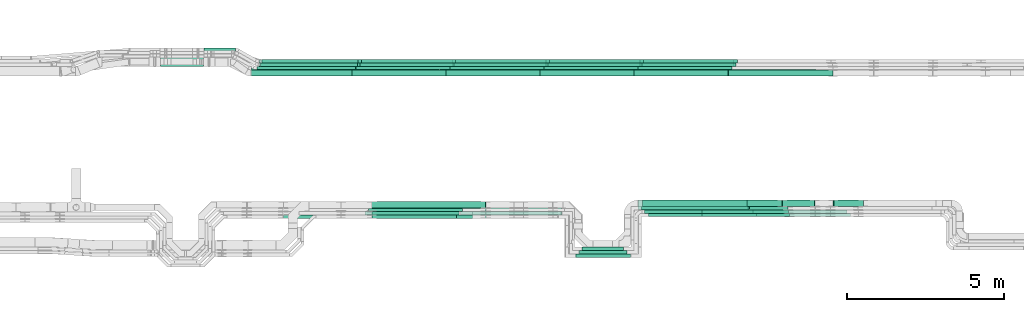
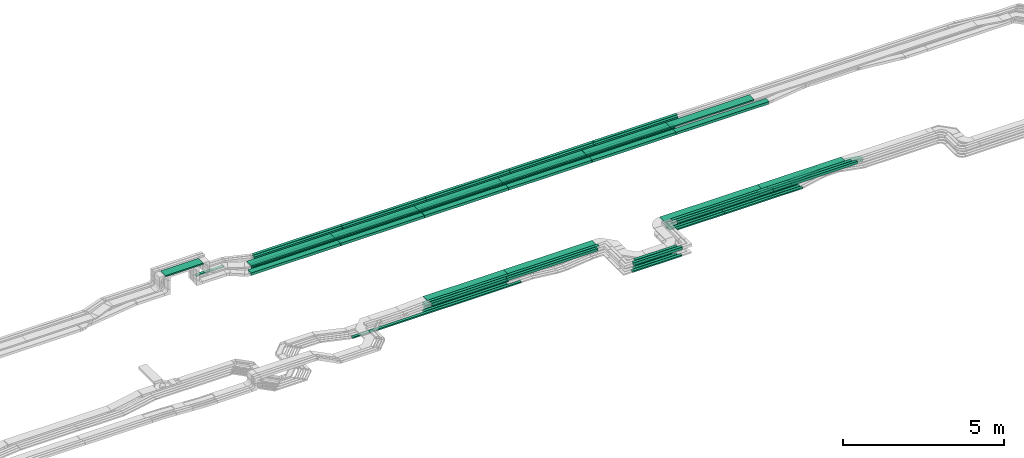
# One storey, part 3 of 33: 70 flow segments.
"""IFC2X3 building model written with IfcOpenShell, lengths in millimetres."""

from ifc_helpers import new_model, entity, si_unit, converted_unit, derived_unit, direction, frame, frame_2d, origin, origin_2d_with_axis, place, context, subcontext, project, spatial, rectangle, extrude, type_object, element, save


model = new_model("IFC2X3")

# Units and contexts
model_context = context("Model", 3, precision=0.01, world=origin(), true_north=direction((6.12303176911189e-17, 1.0)))
body_context = subcontext(model_context, "Body", "Model", "MODEL_VIEW")
ifc_project = project(units=[si_unit("LENGTHUNIT", "METRE", prefix="MILLI"), si_unit("AREAUNIT", "SQUARE_METRE"), si_unit("VOLUMEUNIT", "CUBIC_METRE"), converted_unit("PLANEANGLEUNIT", "DEGREE", entity("IfcRatioMeasure", 0.0174532925199433), si_unit("PLANEANGLEUNIT", "RADIAN"), dimensions=[0, 0, 0, 0, 0, 0, 0]), si_unit("MASSUNIT", "GRAM", prefix="KILO"), derived_unit("MASSDENSITYUNIT", [(si_unit("MASSUNIT", "GRAM", prefix="KILO"), 1), (si_unit("LENGTHUNIT", "METRE"), -3)]), derived_unit("MOMENTOFINERTIAUNIT", [(si_unit("LENGTHUNIT", "METRE"), 4)]), si_unit("TIMEUNIT", "SECOND"), si_unit("FREQUENCYUNIT", "HERTZ"), si_unit("THERMODYNAMICTEMPERATUREUNIT", "DEGREE_CELSIUS"), derived_unit("THERMALTRANSMITTANCEUNIT", [(si_unit("MASSUNIT", "GRAM", prefix="KILO"), 1), (si_unit("THERMODYNAMICTEMPERATUREUNIT", "KELVIN"), -1), (si_unit("TIMEUNIT", "SECOND"), -3)]), derived_unit("VOLUMETRICFLOWRATEUNIT", [(si_unit("LENGTHUNIT", "METRE"), 3), (si_unit("TIMEUNIT", "SECOND"), -1)]), derived_unit("MASSFLOWRATEUNIT", [(si_unit("MASSUNIT", "GRAM", prefix="KILO"), 1), (si_unit("TIMEUNIT", "SECOND"), -1)]), derived_unit("ROTATIONALFREQUENCYUNIT", [(si_unit("TIMEUNIT", "SECOND"), -1)]), si_unit("ELECTRICCURRENTUNIT", "AMPERE"), si_unit("ELECTRICVOLTAGEUNIT", "VOLT"), si_unit("POWERUNIT", "WATT"), si_unit("FORCEUNIT", "NEWTON", prefix="KILO"), si_unit("ILLUMINANCEUNIT", "LUX"), si_unit("LUMINOUSFLUXUNIT", "LUMEN"), si_unit("LUMINOUSINTENSITYUNIT", "CANDELA"), derived_unit("USERDEFINED", [(si_unit("MASSUNIT", "GRAM", prefix="KILO"), -1), (si_unit("LENGTHUNIT", "METRE"), -2), (si_unit("TIMEUNIT", "SECOND"), 3), (si_unit("LUMINOUSFLUXUNIT", "LUMEN"), 1)]), derived_unit("LINEARVELOCITYUNIT", [(si_unit("LENGTHUNIT", "METRE"), 1), (si_unit("TIMEUNIT", "SECOND"), -1)]), si_unit("PRESSUREUNIT", "PASCAL"), derived_unit("USERDEFINED", [(si_unit("LENGTHUNIT", "METRE"), -2), (si_unit("MASSUNIT", "GRAM", prefix="KILO"), 1), (si_unit("TIMEUNIT", "SECOND"), -2)]), derived_unit("LINEARFORCEUNIT", [(si_unit("MASSUNIT", "GRAM", prefix="KILO"), 1), (si_unit("LENGTHUNIT", "METRE"), 1), (si_unit("TIMEUNIT", "SECOND"), -2), (si_unit("LENGTHUNIT", "METRE"), -1)]), derived_unit("PLANARFORCEUNIT", [(si_unit("MASSUNIT", "GRAM", prefix="KILO"), 1), (si_unit("LENGTHUNIT", "METRE"), 1), (si_unit("TIMEUNIT", "SECOND"), -2), (si_unit("LENGTHUNIT", "METRE"), -2)])], contexts=[model_context])

# Site, building, storey
site_placement = place(None, frame((0.0, -0.00077364408347762, 0.0)))
site = spatial("IfcSite", under=ifc_project, at=site_placement, CompositionType="ELEMENT")
building_placement = place(site_placement, origin())
building = spatial("IfcBuilding", under=site, at=building_placement, CompositionType="ELEMENT")
storey_placement = place(building_placement, frame((0.0, 0.0, 8100.0)))
storey = spatial("IfcBuildingStorey", under=building, at=storey_placement, CompositionType="ELEMENT", Elevation=8100.0)

# Flow segments
cable_carrier_segment_type = type_object("IfcCableCarrierSegmentType", PredefinedType="CABLETRAYSEGMENT")
flow_segment_1_placement = place(storey_placement, frame((39344.2553602729, 9754.99855346678, 2800.01096864733)))
element("IfcFlowSegment", 1, at=flow_segment_1_placement, inside=storey, type_object=cable_carrier_segment_type, context=body_context, shape_type="SweptSolid", body=[
    extrude(rectangle(XDim=3242.93310217294, YDim=99.9999999999989, at=frame_2d((-4.32009983342141e-12, 1.08357767203415e-12), x_axis=(1.0, 0.0))), frame((1621.46655108647, 50.0, 0.0), z_axis=(0.0, 0.0, 1.0), x_axis=(-1.0, 0.0, 0.0)), (0.0, 0.0, 1.0), 100.000000000001),
])
flow_segment_2_placement = place(storey_placement, frame((39398.0989392992, 9874.99855346679, 2800.01711339307)))
element("IfcFlowSegment", 2, at=flow_segment_2_placement, inside=storey, type_object=cable_carrier_segment_type, context=body_context, shape_type="SweptSolid", body=[
    extrude(rectangle(XDim=3173.08952314652, YDim=300.000000000001, at=frame_2d((0.0, -1.08002495835535e-12), x_axis=(1.0, 0.0))), frame((1586.54476157326, 150.0, 0.0), z_axis=(0.0, 0.0, 1.0), x_axis=(-1.0, 0.0, 0.0)), (0.0, 0.0, 1.0), 50.0000000000016),
])
flow_segment_3_placement = place(storey_placement, frame((31166.4130823037, 14970.0572451366, 2548.86724903677)))
element("IfcFlowSegment", 3, at=flow_segment_3_placement, inside=storey, type_object=cable_carrier_segment_type, context=body_context, shape_type="SweptSolid", body=[
    extrude(rectangle(XDim=998.256803593107, YDim=99.9999999999989, at=frame_2d((2.1600499167107e-12, 2.16715534406831e-12), x_axis=(1.0, 0.0))), frame((499.128401796551, 50.0, 0.0)), (0.0, 0.0, 1.0), 50.0000000000016),
])
flow_segment_4_placement = place(storey_placement, frame((29783.1990989324, 14480.0572451366, 3324.99867972438)))
element("IfcFlowSegment", 4, at=flow_segment_4_placement, inside=storey, type_object=cable_carrier_segment_type, context=body_context, shape_type="SweptSolid", body=[
    extrude(rectangle(XDim=1363.2139833713, YDim=300.000000000001, at=origin_2d_with_axis()), frame((681.606991685648, 150.0, 0.0)), (0.0, 0.0, 1.0), 50.0000000000016),
])
flow_segment_5_placement = place(storey_placement, frame((45344.895803197, 9694.9904366488, 2799.26960057867)))
element("IfcFlowSegment", 5, at=flow_segment_5_placement, inside=storey, type_object=cable_carrier_segment_type, context=body_context, shape_type="SweptSolid", body=[
    extrude(rectangle(XDim=99.9999999999999, YDim=3442.93310217287, at=frame_2d((-4.32009983342141e-12, -5.43565192856477e-13), x_axis=(0.0, 1.0))), frame((1721.46655109041, 49.9999989516433, 0.0109305123649392), z_axis=(4.01733183785302e-07, 0.000204778842241825, 0.999999979032732), x_axis=(1.0, 0.0, -4.01733192208904e-07)), (0.0, 0.0, 1.0), 100.0),
])
flow_segment_6_placement = place(storey_placement, frame((43147.1884624458, 8512.68960275249, 2800.01096864734)))
element("IfcFlowSegment", 6, at=flow_segment_6_placement, inside=storey, type_object=cable_carrier_segment_type, context=body_context, shape_type="SweptSolid", body=[
    extrude(rectangle(XDim=1512.20104272159, YDim=100.000000000001, at=frame_2d((0.0, 5.43565192856477e-13), x_axis=(1.0, 0.0))), frame((756.100521360796, 50.0, 0.0)), (0.0, 0.0, 1.0), 99.9999999999989),
])
flow_segment_7_placement = place(storey_placement, frame((43027.1884624458, 8402.69104941503, 2799.2813532093)))
element("IfcFlowSegment", 7, at=flow_segment_7_placement, inside=storey, type_object=cable_carrier_segment_type, context=body_context, shape_type="SweptSolid", body=[
    extrude(rectangle(XDim=1757.70736084199, YDim=100.000000000001, at=frame_2d((0.0, 5.43565192856477e-13), x_axis=(1.0, 0.0))), frame((878.853680420995, 50.0, 0.0)), (0.0, 0.0, 1.0), 99.9999999999989),
])
flow_segment_8_placement = place(storey_placement, frame((43217.1884624458, 8622.68960275249, 2544.92549664435)))
element("IfcFlowSegment", 8, at=flow_segment_8_placement, inside=storey, type_object=cable_carrier_segment_type, context=body_context, shape_type="SweptSolid", body=[
    extrude(rectangle(XDim=1332.2010427216, YDim=99.9999999999989, at=frame_2d((0.0, 5.40012479177676e-13), x_axis=(1.0, 0.0))), frame((666.100521360799, 50.0, 0.0)), (0.0, 0.0, 1.0), 50.0000000000016),
])
flow_segment_9_placement = place(storey_placement, frame((43107.1884624458, 8512.68960275249, 2546.31908538351)))
element("IfcFlowSegment", 9, at=flow_segment_9_placement, inside=storey, type_object=cable_carrier_segment_type, context=body_context, shape_type="SweptSolid", body=[
    extrude(rectangle(XDim=1552.2010427216, YDim=99.9999999999989, at=frame_2d((0.0, 5.40012479177676e-13), x_axis=(1.0, 0.0))), frame((776.1005213608, 50.0, 0.0)), (0.0, 0.0, 1.0), 50.0000000000016),
])
flow_segment_10_placement = place(storey_placement, frame((42997.1884624458, 8402.69104941504, 2546.66940793271)))
element("IfcFlowSegment", 10, at=flow_segment_10_placement, inside=storey, type_object=cable_carrier_segment_type, context=body_context, shape_type="SweptSolid", body=[
    extrude(rectangle(XDim=1772.70736117974, YDim=100.000000000001, at=frame_2d((0.0, -5.43565192856477e-13), x_axis=(1.0, 0.0))), frame((886.353680589868, 50.0, 0.0)), (0.0, 0.0, 1.0), 50.0000000000016),
])
flow_segment_11_placement = place(storey_placement, frame((32683.4984883603, 14182.2782357472, 2854.49733895749)))
element("IfcFlowSegment", 11, at=flow_segment_11_placement, inside=storey, type_object=cable_carrier_segment_type, context=body_context, shape_type="SweptSolid", body=[
    extrude(rectangle(XDim=2998.73000000508, YDim=300.000000000001, at=frame_2d((-2.1600499167107e-12, 0.0), x_axis=(1.0, 0.0))), frame((1499.36500000255, 150.0, 0.0)), (0.0, 0.0, 1.0), 50.0000000000016),
])
flow_segment_12_placement = place(storey_placement, frame((32966.2723263535, 14492.2782357466, 2855.0)))
element("IfcFlowSegment", 12, at=flow_segment_12_placement, inside=storey, type_object=cable_carrier_segment_type, context=body_context, shape_type="SweptSolid", body=[
    extrude(rectangle(XDim=3170.75891996771, YDim=99.9999999999989, at=origin_2d_with_axis()), frame((1585.37945998386, 50.0, 0.0)), (0.0, 0.0, 1.0), 99.9999999999989),
])
flow_segment_13_placement = place(storey_placement, frame((33011.9130635549, 14602.2782357466, 2855.0)))
element("IfcFlowSegment", 13, at=flow_segment_13_placement, inside=storey, type_object=cable_carrier_segment_type, context=body_context, shape_type="SweptSolid", body=[
    extrude(rectangle(XDim=3172.25095291534, YDim=99.9999999999989, at=frame_2d((-2.1600499167107e-12, 1.08357767203415e-12), x_axis=(1.0, 0.0))), frame((1586.12547645767, 50.0, 0.0)), (0.0, 0.0, 1.0), 99.9999999999989),
])
flow_segment_14_placement = place(storey_placement, frame((32920.1040531699, 14602.2782357466, 2548.86724903677)))
element("IfcFlowSegment", 14, at=flow_segment_14_placement, inside=storey, type_object=cable_carrier_segment_type, context=body_context, shape_type="SweptSolid", body=[
    extrude(rectangle(XDim=3151.80224385144, YDim=99.9999999999989, at=frame_2d((-2.1600499167107e-12, 0.0), x_axis=(1.0, 0.0))), frame((1575.90112192572, 50.0, 0.0)), (0.0, 0.0, 1.0), 50.0000000000016),
])
flow_segment_15_placement = place(storey_placement, frame((32914.6272166051, 14492.2782357466, 2548.34838425104)))
element("IfcFlowSegment", 15, at=flow_segment_15_placement, inside=storey, type_object=cable_carrier_segment_type, context=body_context, shape_type="SweptSolid", body=[
    extrude(rectangle(XDim=3151.80224385145, YDim=99.9999999999989, at=frame_2d((4.43378667114303e-12, -1.08357767203415e-12), x_axis=(1.0, 0.0))), frame((1575.90112192572, 50.0, 0.0)), (0.0, 0.0, 1.0), 50.0000000000016),
])
flow_segment_16_placement = place(storey_placement, frame((32852.1769039827, 14382.2782357466, 2548.879926104)))
element("IfcFlowSegment", 16, at=flow_segment_16_placement, inside=storey, type_object=cable_carrier_segment_type, context=body_context, shape_type="SweptSolid", body=[
    extrude(rectangle(XDim=3151.80224385145, YDim=99.9999999999989, at=frame_2d((-2.1600499167107e-12, -1.08357767203415e-12), x_axis=(1.0, 0.0))), frame((1575.90112192573, 50.0, 0.0)), (0.0, 0.0, 1.0), 50.0000000000016),
])
flow_segment_17_placement = place(storey_placement, frame((47050.0315011744, 9804.99937591543, 2546.31908538351)))
element("IfcFlowSegment", 17, at=flow_segment_17_placement, inside=storey, type_object=cable_carrier_segment_type, context=body_context, shape_type="SweptSolid", body=[
    extrude(rectangle(XDim=2747.08735792927, YDim=99.9999999999989, at=origin_2d_with_axis()), frame((1373.54367896464, 50.0, 0.0)), (0.0, 0.0, 1.0), 50.0000000000016),
])
flow_segment_18_placement = place(storey_placement, frame((45109.3895051674, 9914.99937591541, 2544.92549664435)))
element("IfcFlowSegment", 18, at=flow_segment_18_placement, inside=storey, type_object=cable_carrier_segment_type, context=body_context, shape_type="SweptSolid", body=[
    extrude(rectangle(XDim=3442.93310217291, YDim=99.9999999999989, at=frame_2d((-4.32009983342141e-12, 0.0), x_axis=(1.0, 0.0))), frame((1721.46655108646, 50.0, 0.0)), (0.0, 0.0, 1.0), 50.0000000000016),
])
flow_segment_19_placement = place(storey_placement, frame((45145.3895051674, 10024.9993759154, 2547.39498136108)))
element("IfcFlowSegment", 19, at=flow_segment_19_placement, inside=storey, type_object=cable_carrier_segment_type, context=body_context, shape_type="SweptSolid", body=[
    extrude(rectangle(XDim=3327.94024484785, YDim=200.000000000002, at=frame_2d((0.0, -1.08713038571295e-12), x_axis=(1.0, 0.0))), frame((1663.97012242393, 100.0, 0.0)), (0.0, 0.0, 1.0), 99.9999999999989),
])
flow_segment_20_placement = place(storey_placement, frame((47050.0315011743, 9695.00084987848, 2546.66940793271)))
element("IfcFlowSegment", 20, at=flow_segment_20_placement, inside=storey, type_object=cable_carrier_segment_type, context=body_context, shape_type="SweptSolid", body=[
    extrude(rectangle(XDim=2786.58976200292, YDim=99.9999999999989, at=origin_2d_with_axis()), frame((1393.29488100146, 50.0, 0.0)), (0.0, 0.0, 1.0), 50.0000000000016),
])
flow_segment_21_placement = place(storey_placement, frame((32672.4468332395, 14174.499226356, 2548.87698397101)))
element("IfcFlowSegment", 21, at=flow_segment_21_placement, inside=storey, type_object=cable_carrier_segment_type, context=body_context, shape_type="SweptSolid", body=[
    extrude(rectangle(XDim=3209.55577942012, YDim=200.000000000002, at=frame_2d((-2.1600499167107e-12, 1.08713038571295e-12), x_axis=(1.0, 0.0))), frame((1604.77788971006, 100.0, 0.0)), (0.0, 0.0, 1.0), 99.9999999999989),
])
flow_segment_22_placement = place(storey_placement, frame((39224.2553602729, 9644.99855346678, 2799.2813532093)))
element("IfcFlowSegment", 22, at=flow_segment_22_placement, inside=storey, type_object=cable_carrier_segment_type, context=body_context, shape_type="SweptSolid", body=[
    extrude(rectangle(XDim=3242.93310217294, YDim=100.000000000001, at=frame_2d((4.32009983342141e-12, 5.43565192856477e-13), x_axis=(1.0, 0.0))), frame((1621.46655108647, 50.0, 0.0), z_axis=(0.0, 0.0, 1.0), x_axis=(-1.0, 0.0, 0.0)), (0.0, 0.0, 1.0), 99.9999999999989),
])
flow_segment_23_placement = place(storey_placement, frame((45008.6950846977, 9924.99937591757, 2796.02568718163)))
element("IfcFlowSegment", 23, at=flow_segment_23_placement, inside=storey, type_object=cable_carrier_segment_type, context=body_context, shape_type="SweptSolid", body=[
    extrude(rectangle(XDim=3498.71922401121, YDim=299.999999995752, at=frame_2d((4.32009983342141e-12, 0.0), x_axis=(1.0, 0.0))), frame((1749.35864760649, 150.0, 1.83688889176971), z_axis=(0.00105003504091696, 0.0, 0.999999448713054), x_axis=(0.999999448713054, 0.0, -0.00105003504091696)), (0.0, 0.0, 1.0), 49.9999999992948),
])
flow_segment_24_placement = place(storey_placement, frame((45219.3885751974, 9804.9993759241, 2799.94084454103)))
element("IfcFlowSegment", 24, at=flow_segment_24_placement, inside=storey, type_object=cable_carrier_segment_type, context=body_context, shape_type="SweptSolid", body=[
    extrude(rectangle(XDim=3442.93310207175, YDim=99.9999999827077, at=frame_2d((0.0, -1.08357767203415e-12), x_axis=(1.0, 0.0))), frame((1721.46655073815, 50.0, 0.0320159615575506)), (0.0, 0.0, 1.0), 99.9999999827065),
])
flow_segment_25_placement = place(storey_placement, frame((36074.4462970112, 14602.2782357467, 2548.86724903677)))
element("IfcFlowSegment", 25, at=flow_segment_25_placement, inside=storey, type_object=cable_carrier_segment_type, context=body_context, shape_type="SweptSolid", body=[
    extrude(rectangle(XDim=2997.46000001016, YDim=99.9999999999989, at=frame_2d((2.1600499167107e-12, 0.0), x_axis=(1.0, 0.0))), frame((1498.73000000508, 50.0, 0.0)), (0.0, 0.0, 1.0), 50.0000000000016),
])
flow_segment_26_placement = place(storey_placement, frame((39074.4462970112, 14602.2782357467, 2548.86724903676)))
element("IfcFlowSegment", 26, at=flow_segment_26_placement, inside=storey, type_object=cable_carrier_segment_type, context=body_context, shape_type="SweptSolid", body=[
    extrude(rectangle(XDim=2997.46000001017, YDim=99.9999999999989, at=frame_2d((0.0, -1.08357767203415e-12), x_axis=(1.0, 0.0))), frame((1498.73000000508, 50.0, 0.0)), (0.0, 0.0, 1.0), 50.0000000000016),
])
flow_segment_27_placement = place(storey_placement, frame((42074.4462970112, 14602.2782357469, 2548.86724903676)))
element("IfcFlowSegment", 27, at=flow_segment_27_placement, inside=storey, type_object=cable_carrier_segment_type, context=body_context, shape_type="SweptSolid", body=[
    extrude(rectangle(XDim=2997.46000001017, YDim=99.9999999999989, at=frame_2d((0.0, 1.08357767203415e-12), x_axis=(1.0, 0.0))), frame((1498.73000000508, 50.0, 0.0)), (0.0, 0.0, 1.0), 50.0000000000016),
])
flow_segment_28_placement = place(storey_placement, frame((45074.4462970112, 14602.2782357471, 2548.86724903676)))
element("IfcFlowSegment", 28, at=flow_segment_28_placement, inside=storey, type_object=cable_carrier_segment_type, context=body_context, shape_type="SweptSolid", body=[
    extrude(rectangle(XDim=2997.46000001017, YDim=99.9999999999989, at=frame_2d((0.0, 2.16715534406831e-12), x_axis=(1.0, 0.0))), frame((1498.73000000508, 50.0, 0.0)), (0.0, 0.0, 1.0), 50.0000000000016),
])
flow_segment_29_placement = place(storey_placement, frame((36304.2553602729, 9754.99855346681, 2546.31908538351)))
element("IfcFlowSegment", 29, at=flow_segment_29_placement, inside=storey, type_object=cable_carrier_segment_type, context=body_context, shape_type="SweptSolid", body=[
    extrude(rectangle(XDim=2997.46000001017, YDim=99.9999999999989, at=origin_2d_with_axis()), frame((1498.73000000508, 50.0, 0.0)), (0.0, 0.0, 1.0), 50.0000000000016),
])
flow_segment_30_placement = place(storey_placement, frame((36068.9694604464, 14492.2782357468, 2548.34838425104)))
element("IfcFlowSegment", 30, at=flow_segment_30_placement, inside=storey, type_object=cable_carrier_segment_type, context=body_context, shape_type="SweptSolid", body=[
    extrude(rectangle(XDim=2997.46000001016, YDim=99.9999999999989, at=frame_2d((2.1600499167107e-12, 2.16715534406831e-12), x_axis=(1.0, 0.0))), frame((1498.73000000508, 50.0, 0.0)), (0.0, 0.0, 1.0), 50.0000000000016),
])
flow_segment_31_placement = place(storey_placement, frame((39068.9694604464, 14492.2782357468, 2548.34838425103)))
element("IfcFlowSegment", 31, at=flow_segment_31_placement, inside=storey, type_object=cable_carrier_segment_type, context=body_context, shape_type="SweptSolid", body=[
    extrude(rectangle(XDim=2997.46000001017, YDim=99.9999999999989, at=frame_2d((0.0, 2.16715534406831e-12), x_axis=(1.0, 0.0))), frame((1498.73000000508, 50.0, 0.0)), (0.0, 0.0, 1.0), 50.0000000000016),
])
flow_segment_32_placement = place(storey_placement, frame((42068.9694604464, 14492.278235747, 2548.34838425104)))
element("IfcFlowSegment", 32, at=flow_segment_32_placement, inside=storey, type_object=cable_carrier_segment_type, context=body_context, shape_type="SweptSolid", body=[
    extrude(rectangle(XDim=2997.46000001017, YDim=99.9999999999989, at=frame_2d((0.0, -1.08357767203415e-12), x_axis=(1.0, 0.0))), frame((1498.73000000508, 50.0, 0.0)), (0.0, 0.0, 1.0), 50.0000000000016),
])
flow_segment_33_placement = place(storey_placement, frame((45068.9694604464, 14492.2782357472, 2548.34838425104)))
element("IfcFlowSegment", 33, at=flow_segment_33_placement, inside=storey, type_object=cable_carrier_segment_type, context=body_context, shape_type="SweptSolid", body=[
    extrude(rectangle(XDim=2997.46000001016, YDim=99.9999999999989, at=frame_2d((-4.32009983342141e-12, 0.0), x_axis=(1.0, 0.0))), frame((1498.73000000508, 50.0, 0.0)), (0.0, 0.0, 1.0), 50.0000000000016),
])
flow_segment_34_placement = place(storey_placement, frame((45140.3895051674, 9804.99937591543, 2546.31908538351)))
element("IfcFlowSegment", 34, at=flow_segment_34_placement, inside=storey, type_object=cable_carrier_segment_type, context=body_context, shape_type="SweptSolid", body=[
    extrude(rectangle(XDim=1907.10199601725, YDim=99.9999999999989, at=origin_2d_with_axis()), frame((953.550998008623, 50.0, 0.0), z_axis=(0.0, 0.0, 1.0), x_axis=(-1.0, 0.0, 0.0)), (0.0, 0.0, 1.0), 50.0000000000016),
])
flow_segment_35_placement = place(storey_placement, frame((36139.5712463111, 14492.2782357466, 2855.0)))
element("IfcFlowSegment", 35, at=flow_segment_35_placement, inside=storey, type_object=cable_carrier_segment_type, context=body_context, shape_type="SweptSolid", body=[
    extrude(rectangle(XDim=2997.46000001016, YDim=99.9999999999989, at=frame_2d((2.1600499167107e-12, -2.16715534406831e-12), x_axis=(1.0, 0.0))), frame((1498.73000000508, 50.0, 0.0)), (0.0, 0.0, 1.0), 99.9999999999989),
])
flow_segment_36_placement = place(storey_placement, frame((39139.5712463111, 14492.2782357466, 2855.0)))
element("IfcFlowSegment", 36, at=flow_segment_36_placement, inside=storey, type_object=cable_carrier_segment_type, context=body_context, shape_type="SweptSolid", body=[
    extrude(rectangle(XDim=2997.46000001017, YDim=99.9999999999989, at=frame_2d((0.0, -2.16715534406831e-12), x_axis=(1.0, 0.0))), frame((1498.73000000508, 50.0, 0.0)), (0.0, 0.0, 1.0), 99.9999999999989),
])
flow_segment_37_placement = place(storey_placement, frame((42139.5712463111, 14492.2782357466, 2855.0)))
element("IfcFlowSegment", 37, at=flow_segment_37_placement, inside=storey, type_object=cable_carrier_segment_type, context=body_context, shape_type="SweptSolid", body=[
    extrude(rectangle(XDim=2997.46000001017, YDim=99.9999999999989, at=frame_2d((0.0, -1.08357767203415e-12), x_axis=(1.0, 0.0))), frame((1498.73000000508, 50.0, 0.0)), (0.0, 0.0, 1.0), 99.9999999999989),
])
flow_segment_38_placement = place(storey_placement, frame((45139.5712463111, 14492.2782357469, 2855.0)))
element("IfcFlowSegment", 38, at=flow_segment_38_placement, inside=storey, type_object=cable_carrier_segment_type, context=body_context, shape_type="SweptSolid", body=[
    extrude(rectangle(XDim=2997.46000001017, YDim=99.9999999999989, at=origin_2d_with_axis()), frame((1498.73000000508, 50.0, 0.0)), (0.0, 0.0, 1.0), 99.9999999999989),
])
for number, where in (
    (39, (35884.5426126494, 14174.499226356, 2548.87698397101)),
    (40, (38884.5426126494, 14174.499226356, 2548.876983971)),
):
    element("IfcFlowSegment", number, at=place(storey_placement, frame(where)), inside=storey, type_object=cable_carrier_segment_type, context=body_context, shape_type="SweptSolid", body=[
        extrude(rectangle(XDim=2997.46000001016, YDim=199.999999999998, at=frame_2d((2.1600499167107e-12, 0.0), x_axis=(1.0, 0.0))), frame((1498.73000000508, 100.0, 0.0)), (0.0, 0.0, 1.0), 99.9999999999989),
    ])
flow_segment_39_placement = place(storey_placement, frame((41884.5426126494, 14174.499226356, 2548.876983971)))
element("IfcFlowSegment", 41, at=flow_segment_39_placement, inside=storey, type_object=cable_carrier_segment_type, context=body_context, shape_type="SweptSolid", body=[
    extrude(rectangle(XDim=2997.46000001017, YDim=199.999999999998, at=frame_2d((0.0, 2.16715534406831e-12), x_axis=(1.0, 0.0))), frame((1498.73000000508, 100.0, 0.0)), (0.0, 0.0, 1.0), 99.9999999999989),
])
flow_segment_40_placement = place(storey_placement, frame((44884.5426126494, 14174.499226356, 2548.87698397099)))
element("IfcFlowSegment", 42, at=flow_segment_40_placement, inside=storey, type_object=cable_carrier_segment_type, context=body_context, shape_type="SweptSolid", body=[
    extrude(rectangle(XDim=2997.46000001016, YDim=199.999999999998, at=frame_2d((-4.32009983342141e-12, 0.0), x_axis=(1.0, 0.0))), frame((1498.73000000508, 100.0, 0.0)), (0.0, 0.0, 1.0), 99.9999999999989),
])
flow_segment_41_placement = place(storey_placement, frame((47884.5426126494, 14174.499226356, 2548.87698397099)))
element("IfcFlowSegment", 43, at=flow_segment_41_placement, inside=storey, type_object=cable_carrier_segment_type, context=body_context, shape_type="SweptSolid", body=[
    extrude(rectangle(XDim=3332.70440700738, YDim=199.999999999998, at=frame_2d((0.0, -1.08002495835535e-12), x_axis=(1.0, 0.0))), frame((1666.35220350369, 100.0, 0.0)), (0.0, 0.0, 1.0), 99.9999999999989),
])
for number, where in (
    (44, (35684.7684883553, 14182.2782357472, 2854.49733895749)),
    (45, (38684.7684883553, 14182.2782357472, 2854.49733895749)),
):
    element("IfcFlowSegment", number, at=place(storey_placement, frame(where)), inside=storey, type_object=cable_carrier_segment_type, context=body_context, shape_type="SweptSolid", body=[
        extrude(rectangle(XDim=2997.46000001016, YDim=300.000000000001, at=frame_2d((2.1600499167107e-12, 0.0), x_axis=(1.0, 0.0))), frame((1498.73000000508, 150.0, 0.0)), (0.0, 0.0, 1.0), 50.0000000000016),
    ])
flow_segment_42_placement = place(storey_placement, frame((41684.7684883553, 14182.2782357472, 2854.4973389575)))
element("IfcFlowSegment", 46, at=flow_segment_42_placement, inside=storey, type_object=cable_carrier_segment_type, context=body_context, shape_type="SweptSolid", body=[
    extrude(rectangle(XDim=2997.46000001017, YDim=300.000000000001, at=origin_2d_with_axis()), frame((1498.73000000508, 150.0, 0.0)), (0.0, 0.0, 1.0), 50.0000000000038),
])
flow_segment_43_placement = place(storey_placement, frame((44684.7684883553, 14182.2782357474, 2854.4973389575)))
element("IfcFlowSegment", 47, at=flow_segment_43_placement, inside=storey, type_object=cable_carrier_segment_type, context=body_context, shape_type="SweptSolid", body=[
    extrude(rectangle(XDim=2997.46000001017, YDim=300.000000000001, at=frame_2d((0.0, 1.08002495835535e-12), x_axis=(1.0, 0.0))), frame((1498.73000000508, 150.0, 0.0)), (0.0, 0.0, 1.0), 50.0000000000016),
])
flow_segment_44_placement = place(storey_placement, frame((47684.7684883553, 14182.2782357476, 2854.4973389575)))
element("IfcFlowSegment", 48, at=flow_segment_44_placement, inside=storey, type_object=cable_carrier_segment_type, context=body_context, shape_type="SweptSolid", body=[
    extrude(rectangle(XDim=2997.46000001016, YDim=300.000000000001, at=frame_2d((-4.32009983342141e-12, 2.17426077142591e-12), x_axis=(1.0, 0.0))), frame((1498.73000000508, 150.0, 0.0)), (0.0, 0.0, 1.0), 50.0000000000038),
])
flow_segment_45_placement = place(storey_placement, frame((36493.2395962174, 9974.99855349166, 2546.76460459149)))
element("IfcFlowSegment", 49, at=flow_segment_45_placement, inside=storey, type_object=cable_carrier_segment_type, context=body_context, shape_type="SweptSolid", body=[
    extrude(rectangle(XDim=3655.89665624518, YDim=199.999999950251, at=frame_2d((0.0, 1.08002495835535e-12), x_axis=(1.0, 0.0))), frame((1827.94830094897, 100.0, 0.31518876265219), z_axis=(0.000172427610674945, 0.0, 0.99999998513436), x_axis=(0.99999998513436, 0.0, -0.000172427610674945)), (0.0, 0.0, 1.0), 99.999999975123),
])
flow_segment_46_placement = place(storey_placement, frame((48475.8697500051, 10024.9993759154, 2547.39498136108)))
element("IfcFlowSegment", 50, at=flow_segment_46_placement, inside=storey, type_object=cable_carrier_segment_type, context=body_context, shape_type="SweptSolid", body=[
    extrude(rectangle(XDim=1127.1073315062, YDim=199.999999999998, at=frame_2d((-4.32009983342141e-12, 0.0), x_axis=(1.0, 0.0))), frame((563.553665753103, 100.0, 0.0)), (0.0, 0.0, 1.0), 99.9999999999989),
])
flow_segment_47_placement = place(storey_placement, frame((48509.9523785002, 9924.99937591544, 2792.87558205849)))
element("IfcFlowSegment", 51, at=flow_segment_47_placement, inside=storey, type_object=cable_carrier_segment_type, context=body_context, shape_type="SweptSolid", body=[
    extrude(rectangle(XDim=2997.46000001016, YDim=300.000000000001, at=frame_2d((0.0, 1.08002495835535e-12), x_axis=(1.0, 0.0))), frame((1498.72917377479, 150.0, 1.57371901689521), z_axis=(0.0010500350409279, 0.0, 0.999999448713054), x_axis=(0.999999448713054, 0.0, -0.0010500350409279)), (0.0, 0.0, 1.0), 50.0000000000008),
])
flow_segment_48_placement = place(storey_placement, frame((36414.2553602729, 9864.99855346681, 2544.92549664434)))
element("IfcFlowSegment", 52, at=flow_segment_48_placement, inside=storey, type_object=cable_carrier_segment_type, context=body_context, shape_type="SweptSolid", body=[
    extrude(rectangle(XDim=2997.46000001016, YDim=99.9999999999989, at=frame_2d((-2.1600499167107e-12, 0.0), x_axis=(1.0, 0.0))), frame((1498.73000000508, 50.0, 0.0), z_axis=(0.0, 0.0, 1.0), x_axis=(-1.0, 0.0, 0.0)), (0.0, 0.0, 1.0), 50.0000000000016),
])
flow_segment_49_placement = place(storey_placement, frame((33696.8392112639, 9644.9985534668, 2546.63308707341)))
element("IfcFlowSegment", 53, at=flow_segment_49_placement, inside=storey, type_object=cable_carrier_segment_type, context=body_context, shape_type="SweptSolid", body=[
    extrude(rectangle(XDim=6031.01020597482, YDim=100.000000000001, at=frame_2d((-2.27373675443232e-12, 0.0), x_axis=(1.0, 0.0))), frame((3015.50510298741, 50.0, 0.0), z_axis=(0.0, 0.0, 1.0), x_axis=(-1.0, 0.0, 0.0)), (0.0, 0.0, 1.0), 50.0000000000016),
])
flow_segment_50_placement = place(storey_placement, frame((48790.3689019508, 9695.00067454256, 2799.27842851121)))
element("IfcFlowSegment", 54, at=flow_segment_50_placement, inside=storey, type_object=cable_carrier_segment_type, context=body_context, shape_type="SweptSolid", body=[
    extrude(rectangle(XDim=2997.46000001017, YDim=99.9999999999989, at=origin_2d_with_axis()), frame((1498.73000000492, 50.0, 0.000704383717800283)), (0.0, 0.0, 1.0), 100.000000000001),
])
flow_segment_51_placement = place(storey_placement, frame((36186.70401646, 14602.2782357466, 2855.0)))
element("IfcFlowSegment", 55, at=flow_segment_51_placement, inside=storey, type_object=cable_carrier_segment_type, context=body_context, shape_type="SweptSolid", body=[
    extrude(rectangle(XDim=2997.46000001016, YDim=99.9999999999989, at=frame_2d((2.1600499167107e-12, 0.0), x_axis=(1.0, 0.0))), frame((1498.73000000508, 50.0, 0.0)), (0.0, 0.0, 1.0), 99.9999999999989),
])
flow_segment_52_placement = place(storey_placement, frame((39186.70401646, 14602.2782357466, 2855.0)))
element("IfcFlowSegment", 56, at=flow_segment_52_placement, inside=storey, type_object=cable_carrier_segment_type, context=body_context, shape_type="SweptSolid", body=[
    extrude(rectangle(XDim=2997.46000001017, YDim=99.9999999999989, at=origin_2d_with_axis()), frame((1498.73000000508, 50.0, 0.0)), (0.0, 0.0, 1.0), 99.9999999999989),
])
flow_segment_53_placement = place(storey_placement, frame((42186.70401646, 14602.2782357466, 2855.0)))
element("IfcFlowSegment", 57, at=flow_segment_53_placement, inside=storey, type_object=cable_carrier_segment_type, context=body_context, shape_type="SweptSolid", body=[
    extrude(rectangle(XDim=2997.46000001016, YDim=99.9999999999989, at=frame_2d((-4.32009983342141e-12, 1.08357767203415e-12), x_axis=(1.0, 0.0))), frame((1498.73000000508, 50.0, 0.0)), (0.0, 0.0, 1.0), 99.9999999999989),
])
flow_segment_54_placement = place(storey_placement, frame((45186.70401646, 14602.2782357469, 2855.0)))
element("IfcFlowSegment", 58, at=flow_segment_54_placement, inside=storey, type_object=cable_carrier_segment_type, context=body_context, shape_type="SweptSolid", body=[
    extrude(rectangle(XDim=2997.46000001017, YDim=99.9999999999989, at=origin_2d_with_axis()), frame((1498.73000000508, 50.0, 0.0)), (0.0, 0.0, 1.0), 99.9999999999989),
])
flow_segment_55_placement = place(storey_placement, frame((36006.519147824, 14382.2782357468, 2548.879926104)))
element("IfcFlowSegment", 59, at=flow_segment_55_placement, inside=storey, type_object=cable_carrier_segment_type, context=body_context, shape_type="SweptSolid", body=[
    extrude(rectangle(XDim=2997.46000001016, YDim=99.9999999999989, at=frame_2d((2.1600499167107e-12, 0.0), x_axis=(1.0, 0.0))), frame((1498.73000000508, 50.0, 0.0)), (0.0, 0.0, 1.0), 50.0000000000016),
])
flow_segment_56_placement = place(storey_placement, frame((39006.519147824, 14382.2782357468, 2548.879926104)))
element("IfcFlowSegment", 60, at=flow_segment_56_placement, inside=storey, type_object=cable_carrier_segment_type, context=body_context, shape_type="SweptSolid", body=[
    extrude(rectangle(XDim=2997.46000001016, YDim=99.9999999999989, at=frame_2d((2.1600499167107e-12, -1.08357767203415e-12), x_axis=(1.0, 0.0))), frame((1498.73000000508, 50.0, 0.0)), (0.0, 0.0, 1.0), 50.0000000000038),
])
flow_segment_57_placement = place(storey_placement, frame((42006.519147824, 14382.278235747, 2548.879926104)))
element("IfcFlowSegment", 61, at=flow_segment_57_placement, inside=storey, type_object=cable_carrier_segment_type, context=body_context, shape_type="SweptSolid", body=[
    extrude(rectangle(XDim=2997.46000001017, YDim=99.9999999999989, at=frame_2d((0.0, -1.08357767203415e-12), x_axis=(1.0, 0.0))), frame((1498.73000000508, 50.0, 0.0)), (0.0, 0.0, 1.0), 50.0000000000016),
])
flow_segment_58_placement = place(storey_placement, frame((45006.519147824, 14382.2782357471, 2548.879926104)))
element("IfcFlowSegment", 62, at=flow_segment_58_placement, inside=storey, type_object=cable_carrier_segment_type, context=body_context, shape_type="SweptSolid", body=[
    extrude(rectangle(XDim=2997.46000001017, YDim=99.9999999999989, at=frame_2d((0.0, -2.16715534406831e-12), x_axis=(1.0, 0.0))), frame((1498.73000000508, 50.0, 0.0)), (0.0, 0.0, 1.0), 50.0000000000016),
])
flow_segment_59_placement = place(storey_placement, frame((48554.8626073301, 9914.99937591541, 2544.92549664435)))
element("IfcFlowSegment", 63, at=flow_segment_59_placement, inside=storey, type_object=cable_carrier_segment_type, context=body_context, shape_type="SweptSolid", body=[
    extrude(rectangle(XDim=1227.26174799622, YDim=99.9999999999989, at=frame_2d((-4.32009983342141e-12, 0.0), x_axis=(1.0, 0.0))), frame((613.630873998112, 50.0, 0.0)), (0.0, 0.0, 1.0), 50.0000000000016),
])
flow_segment_60_placement = place(storey_placement, frame((45329.8958236255, 9695.00084987848, 2546.66940793271)))
element("IfcFlowSegment", 64, at=flow_segment_60_placement, inside=storey, type_object=cable_carrier_segment_type, context=body_context, shape_type="SweptSolid", body=[
    extrude(rectangle(XDim=1717.59567755898, YDim=99.9999999999989, at=frame_2d((0.0, 1.08357767203415e-12), x_axis=(1.0, 0.0))), frame((858.797838779491, 50.0, 0.0), z_axis=(0.0, 0.0, 1.0), x_axis=(-1.0, 0.0, 0.0)), (0.0, 0.0, 1.0), 50.0000000000016),
])
flow_segment_61_placement = place(storey_placement, frame((48664.8615186737, 9804.99937591546, 2799.87557095896)))
element("IfcFlowSegment", 65, at=flow_segment_61_placement, inside=storey, type_object=cable_carrier_segment_type, context=body_context, shape_type="SweptSolid", body=[
    extrude(rectangle(XDim=2997.46000001016, YDim=99.9999999999989, at=origin_2d_with_axis()), frame((1498.72999965033, 50.0, 0.0326091558287942)), (0.0, 0.0, 1.0), 100.000000000002),
])
flow_segment_62_placement = place(storey_placement, frame((49605.5973232689, 10024.9993759154, 2548.86300354974)))
element("IfcFlowSegment", 66, at=flow_segment_62_placement, inside=storey, type_object=cable_carrier_segment_type, context=body_context, shape_type="SweptSolid", body=[
    extrude(rectangle(XDim=99.9999999999985, YDim=199.999999999998, at=origin_2d_with_axis()), frame((7.91045143744338, 100.0, 49.3702821346599), z_axis=(0.987405642693212, 0.0, 0.158209028748697), x_axis=(-0.158209028748697, 0.0, 0.987405642693212)), (0.0, 0.0, 1.0), 1040.01743236839),
])
flow_segment_63_placement = place(storey_placement, frame((51231.0497364687, 10024.9993759154, 2551.69227119781)))
element("IfcFlowSegment", 67, at=flow_segment_63_placement, inside=storey, type_object=cable_carrier_segment_type, context=body_context, shape_type="SweptSolid", body=[
    extrude(rectangle(XDim=100.0, YDim=200.000000000002, at=frame_2d((0.0, 0.0), x_axis=(0.0, 1.0))), frame((8.43159831162191, 100.0, 210.977505327614), z_axis=(0.985679085688939, 0.0, -0.168631966232437), x_axis=(0.0, 1.0, 0.0)), (0.0, 0.0, 1.0), 958.854686070293),
])
flow_segment_64_placement = place(storey_placement, frame((36523.4488466685, 9874.99855346676, 2800.01711339307)))
element("IfcFlowSegment", 68, at=flow_segment_64_placement, inside=storey, type_object=cable_carrier_segment_type, context=body_context, shape_type="SweptSolid", body=[
    extrude(rectangle(XDim=2872.11009264089, YDim=300.000000000001, at=origin_2d_with_axis()), frame((1436.05504632044, 150.0, 0.0), z_axis=(0.0, 0.0, 1.0), x_axis=(-1.0, 0.0, 0.0)), (0.0, 0.0, 1.0), 50.0000000000016),
])
flow_segment_65_placement = place(storey_placement, frame((36524.0811625181, 9754.99855346677, 2800.01096864734)))
element("IfcFlowSegment", 69, at=flow_segment_65_placement, inside=storey, type_object=cable_carrier_segment_type, context=body_context, shape_type="SweptSolid", body=[
    extrude(rectangle(XDim=2817.63419776496, YDim=99.9999999999989, at=frame_2d((-2.1600499167107e-12, 0.0), x_axis=(1.0, 0.0))), frame((1408.81709888248, 50.0, 0.0), z_axis=(0.0, 0.0, 1.0), x_axis=(-1.0, 0.0, 0.0)), (0.0, 0.0, 1.0), 99.9999999999968),
])
flow_segment_66_placement = place(storey_placement, frame((36524.0811625181, 9644.99855346677, 2799.2813532093)))
element("IfcFlowSegment", 70, at=flow_segment_66_placement, inside=storey, type_object=cable_carrier_segment_type, context=body_context, shape_type="SweptSolid", body=[
    extrude(rectangle(XDim=2697.63419776494, YDim=99.9999999999989, at=frame_2d((2.1600499167107e-12, 0.0), x_axis=(1.0, 0.0))), frame((1348.81709888247, 50.0, 0.0), z_axis=(0.0, 0.0, 1.0), x_axis=(-1.0, 0.0, 0.0)), (0.0, 0.0, 1.0), 99.9999999999989),
])

save(model, "model.ifc")
